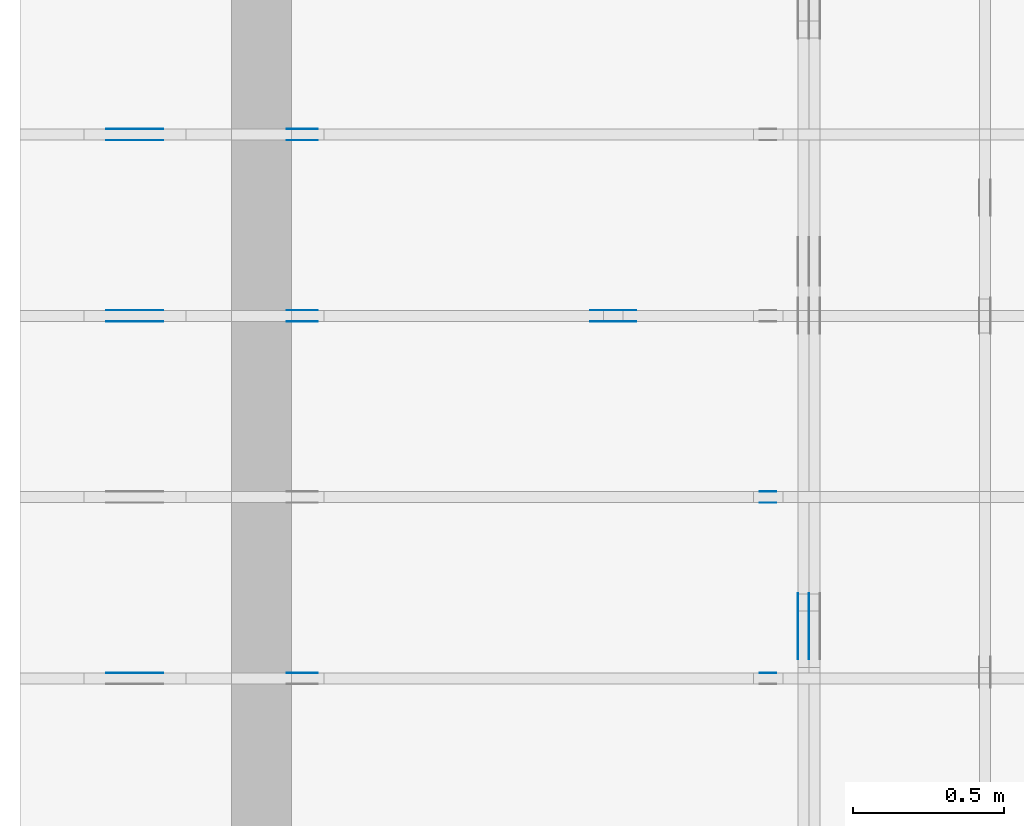
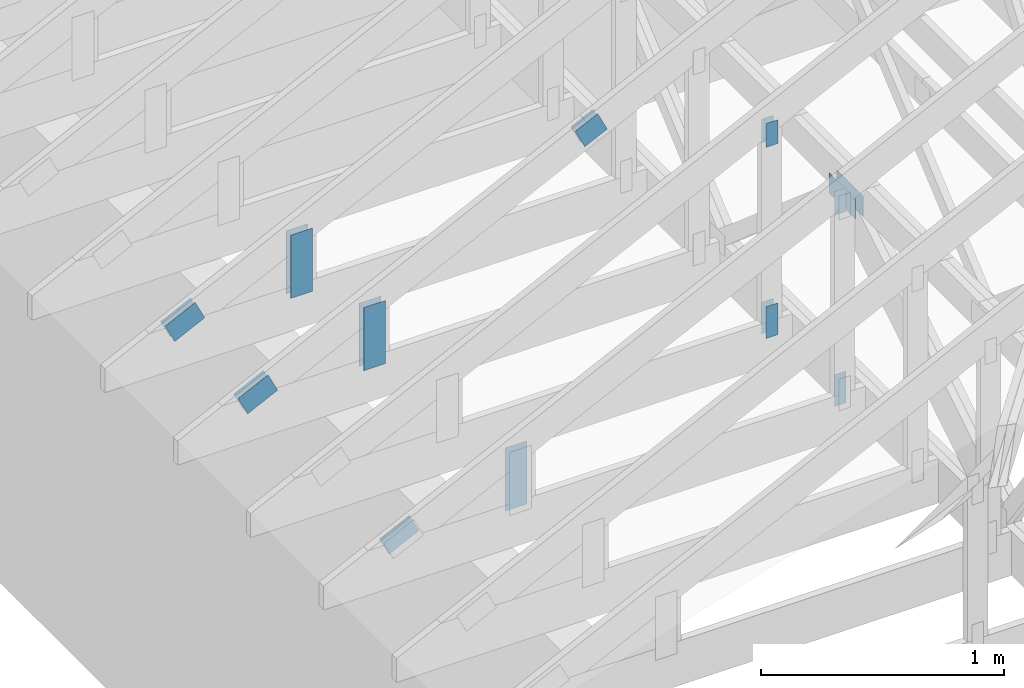
# One storey, part 65 of 159: 20 plates, 5 elements without a shape of their own.
"""IFC2X3 building model written with IfcOpenShell, lengths in millimetres."""

from ifc_helpers import new_model, si_unit, frame, origin, origin_with_axes, origin_2d, place, context, project, spatial, faceted_brep, element, aggregate, save


model = new_model("IFC2X3")

# Units and contexts
model_context = context("Model", 3, precision=1e-05, world=origin())
plan_context = context("Plan", 2, precision=1e-05, world=origin_2d())
ifc_project = project(units=[si_unit("LENGTHUNIT", "METRE", prefix="MILLI"), si_unit("AREAUNIT", "SQUARE_METRE"), si_unit("VOLUMEUNIT", "CUBIC_METRE"), si_unit("SOLIDANGLEUNIT", "STERADIAN"), si_unit("PLANEANGLEUNIT", "RADIAN"), si_unit("MASSUNIT", "GRAM"), si_unit("TIMEUNIT", "SECOND"), si_unit("THERMODYNAMICTEMPERATUREUNIT", "DEGREE_CELSIUS"), si_unit("LUMINOUSINTENSITYUNIT", "LUMEN")], contexts=[model_context, plan_context])

# Site, building, storey
site_placement = place(None, origin_with_axes())
site = spatial("IfcSite", under=ifc_project, at=site_placement, CompositionType="ELEMENT")
building_placement = place(site_placement, origin_with_axes())
building = spatial("IfcBuilding", under=site, at=building_placement, Name="Plan 1", CompositionType="ELEMENT")
storey_placement = place(building_placement, origin_with_axes())
storey = spatial("IfcBuildingStorey", under=building, at=storey_placement, Name="Etasje 1", CompositionType="ELEMENT", Elevation=0.0)

# Assembly, plates
assembly_1_placement = place(storey_placement, frame((-700.000000000007, 4482.000534935255, 1.1021457184401395e-15), z_axis=(0.0, -1.0, 6.123031769111886e-17), x_axis=(1.0, 0.0, 0.0)))
assembly_1 = element("IfcElementAssembly", 1, at=assembly_1_placement, inside=storey, Name="S1 (23)", AssemblyPlace="FACTORY", PredefinedType="TRUSS")
plate_1_placement = place(assembly_1_placement, frame((331.1100183694873, 141.8615904247371, 0.0), z_axis=(0.0, 0.0, 1.0), x_axis=(0.8987940462991673, 0.43837114678907735, 0.0)))
plate_1 = element("IfcPlate", 2, at=plate_1_placement, Name="GNT100S 103x159", context=model_context, shape_type="Brep", body=[
    faceted_brep([(158.99998918560436, 103.00001264929408, 1.0), (1.0552279888997873e-05, 103.00001264929408, 1.0), (3.170298271015781e-06, 1.2203795506593451e-05, 1.0), (159.0000092326402, 1.2203795506593451e-05, 1.0), (1.0552279888997873e-05, 103.00001264929408, 1.2922388999378885e-21), (158.99998918560436, 103.00001264929408, 1.947123970143804e-14), (159.0000092326402, 0.0, 1.9471242156410782e-14), (3.170298271015781e-06, 0.0, 3.8823674061980226e-22), (159.0000000000001, 1.1149522122547493e-05, 4.8075085841285717e-32), (159.0000000000001, 1.1149522122608723e-05, 1.0), (5.684341886080802e-14, 1.1149522151815584e-05, 1.0), (5.684341886080802e-14, 1.1149522151754354e-05, 0.0), (159.0000000000001, 103.00001114952212, 0.0), (159.0000000000001, 103.00001114952212, 1.0), (159.0000000000001, 1.1149522123332645e-05, 1.0), (159.0000000000001, 1.1149522123332645e-05, 0.0), (0.0, 103.00001114952218, 0.0), (0.0, 103.00001114952218, 1.0), (159.0000000000001, 103.00001114952214, 1.0), (159.0000000000001, 103.00001114952214, 7.888609052210118e-31), (5.684342142797745e-14, 1.1149522151754354e-05, -1.571885995307892e-37), (5.690465174566857e-14, 1.1149522151754354e-05, 1.0), (2.377690857548259e-14, 103.00001114952218, 1.0), (2.371567825779147e-14, 103.00001114952218, -1.4521185139849321e-30)], [[[0, 1, 2, 3]], [[4, 5, 6, 7]], [[8, 9, 10, 11]], [[12, 13, 14, 15]], [[16, 17, 18, 19]], [[20, 21, 22, 23]]]),
])
plate_2_placement = place(assembly_1_placement, frame((331.1100183694873, 141.8615904247371, -37.00000000000001), z_axis=(0.0, 0.0, 1.0), x_axis=(0.8987940462991673, 0.43837114678907735, 0.0)))
plate_2 = element("IfcPlate", 3, at=plate_2_placement, Name="GNT100S 103x159", context=model_context, shape_type="Brep", body=[
    faceted_brep([(158.99998918560436, 103.00001264929408, 1.0), (1.0552279888997873e-05, 103.00001264929408, 1.0), (3.170298271015781e-06, 1.2203795506593451e-05, 1.0), (159.0000092326402, 1.2203795506593451e-05, 1.0), (1.0552279888997873e-05, 103.00001264929408, 1.2922388999378885e-21), (158.99998918560436, 103.00001264929408, 1.947123970143804e-14), (159.0000092326402, 0.0, 1.9471242156410782e-14), (3.170298271015781e-06, 0.0, 3.8823674061980226e-22), (159.0000000000001, 1.1149522122547493e-05, 4.8075085841285717e-32), (159.0000000000001, 1.1149522122608723e-05, 1.0), (5.684341886080802e-14, 1.1149522151815584e-05, 1.0), (5.684341886080802e-14, 1.1149522151754354e-05, 0.0), (159.0000000000001, 103.00001114952212, 0.0), (159.0000000000001, 103.00001114952212, 1.0), (159.0000000000001, 1.1149522123332645e-05, 1.0), (159.0000000000001, 1.1149522123332645e-05, 0.0), (0.0, 103.00001114952218, 0.0), (0.0, 103.00001114952218, 1.0), (159.0000000000001, 103.00001114952214, 1.0), (159.0000000000001, 103.00001114952214, 7.888609052210118e-31), (5.684342142797745e-14, 1.1149522151754354e-05, -1.571885995307892e-37), (5.690465174566857e-14, 1.1149522151754354e-05, 1.0), (2.377690857548259e-14, 103.00001114952218, 1.0), (2.371567825779147e-14, 103.00001114952218, -1.4521185139849321e-30)], [[[0, 1, 2, 3]], [[4, 5, 6, 7]], [[8, 9, 10, 11]], [[12, 13, 14, 15]], [[16, 17, 18, 19]], [[20, 21, 22, 23]]]),
])
plate_3_placement = place(assembly_1_placement, frame((986.0125131960367, 165.43966674804688, 0.0), z_axis=(0.0, 0.0, 1.0), x_axis=(6.123031769111886e-17, 1.0, 0.0)))
plate_3 = element("IfcPlate", 4, at=plate_3_placement, Name="GNT100S 103x317", context=model_context, shape_type="Brep", body=[
    faceted_brep([(317.0, 103.00000098900546, 1.0), (0.0, 103.00000098900546, 1.0), (0.0, 9.89005457086023e-07, 1.0), (317.0, 9.89005457086023e-07, 1.0), (0.0, 103.00000098900546, 0.0), (317.0, 103.00000098900546, 3.882002141616936e-14), (317.0, 9.89005457086023e-07, 3.882002141616936e-14), (0.0, 9.89005457086023e-07, 0.0), (317.0000058634589, -5.82300332013184e-14, 3.565443432081125e-30), (317.0000058634589, -5.816880288362728e-14, 1.0), (5.863458909516339e-06, 6.122924062676347e-17, 1.0), (5.863458909516339e-06, -1.0770643553955205e-21, 6.594899265464787e-38), (317.0000058634589, 103.0, 0.0), (317.0000058634589, 103.0, 1.0), (317.0000058634589, 0.0, 1.0), (317.0000058634589, 0.0, 0.0), (5.863458909516339e-06, 103.0, 0.0), (5.863458909516339e-06, 103.0, 1.0), (317.0000058634589, 102.99999999999999, 1.0), (317.0000058634589, 102.99999999999999, -1.5777218104420236e-30), (5.863458909516339e-06, 0.0, 0.0), (5.8634589095775695e-06, -7.498303609110687e-33, 1.0), (5.863458922191015e-06, 103.0, 1.0), (5.863458922129785e-06, 103.0, -7.723252732077687e-31)], [[[0, 1, 2, 3]], [[4, 5, 6, 7]], [[8, 9, 10, 11]], [[12, 13, 14, 15]], [[16, 17, 18, 19]], [[20, 21, 22, 23]]]),
])
plate_4_placement = place(assembly_1_placement, frame((986.0125131960367, 165.43966674804688, -37.0), z_axis=(0.0, 0.0, 1.0), x_axis=(6.123031769111886e-17, 1.0, 0.0)))
plate_4 = element("IfcPlate", 5, at=plate_4_placement, Name="GNT100S 103x317", context=model_context, shape_type="Brep", body=[
    faceted_brep([(317.0, 103.00000098900546, 1.0), (0.0, 103.00000098900546, 1.0), (0.0, 9.89005457086023e-07, 1.0), (317.0, 9.89005457086023e-07, 1.0), (0.0, 103.00000098900546, 0.0), (317.0, 103.00000098900546, 3.882002141616936e-14), (317.0, 9.89005457086023e-07, 3.882002141616936e-14), (0.0, 9.89005457086023e-07, 0.0), (317.0000058634589, -5.82300332013184e-14, 3.565443432081125e-30), (317.0000058634589, -5.816880288362728e-14, 1.0), (5.863458909516339e-06, 6.122924062676347e-17, 1.0), (5.863458909516339e-06, -1.0770643553955205e-21, 6.594899265464787e-38), (317.0000058634589, 103.0, 0.0), (317.0000058634589, 103.0, 1.0), (317.0000058634589, 0.0, 1.0), (317.0000058634589, 0.0, 0.0), (5.863458909516339e-06, 103.0, 0.0), (5.863458909516339e-06, 103.0, 1.0), (317.0000058634589, 102.99999999999999, 1.0), (317.0000058634589, 102.99999999999999, -1.5777218104420236e-30), (5.863458909516339e-06, 0.0, 0.0), (5.8634589095775695e-06, -7.498303609110687e-33, 1.0), (5.863458922191015e-06, 103.0, 1.0), (5.863458922129785e-06, 103.0, -7.723252732077687e-31)], [[[0, 1, 2, 3]], [[4, 5, 6, 7]], [[8, 9, 10, 11]], [[12, 13, 14, 15]], [[16, 17, 18, 19]], [[20, 21, 22, 23]]]),
])
plate_5_placement = place(assembly_1_placement, frame((1932.9423828125007, 923.1274414062502, 0.0), z_axis=(0.0, 0.0, 1.0), x_axis=(0.8987940462991673, 0.43837114678907735, 0.0)))
plate_5 = element("IfcPlate", 6, at=plate_5_placement, Name="GNT100S 103x119", context=model_context, shape_type="Brep", body=[
    faceted_brep([(119.00004770909891, 103.00001416000737, 1.0), (1.4070994438952766e-05, 103.00001416000737, 1.0), (0.0, 0.0, 1.0), (119.00006039415575, 0.0, 1.0), (1.4070994438952766e-05, 103.00001416000737, 1.7231429194540894e-21), (119.00004770909891, 103.00001416000737, 1.4572821452972854e-14), (119.00006039415575, 6.439198386942735e-06, 1.4572823006392977e-14), (0.0, 6.439198386942735e-06, 0.0), (119.0000491479459, 6.275306616022548e-06, 1.8278989817433488e-30), (119.0000491479459, 6.2753066160837785e-06, 1.0), (4.9147945446748054e-05, 6.27530653224977e-06, 1.0), (4.9147945446748054e-05, 6.27530653218854e-06, 7.52316384526264e-37), (119.0000491479459, 103.00000627530653, 2.68212707775144e-29), (119.0000491479459, 103.00000627530653, 1.0), (119.0000491479459, 6.275306645875389e-06, 1.0), (119.0000491479459, 6.275306645875389e-06, 0.0), (4.9147945901495405e-05, 103.00000627530653, 0.0), (4.9147945901495405e-05, 103.00000627530653, 1.0), (119.00004914794545, 103.00000627530652, 1.0), (119.00004914794545, 103.00000627530652, -7.888609052210118e-31), (4.9147945446748054e-05, 6.2753065321885515e-06, -3.76158192263132e-37), (4.9147945446809284e-05, 6.2753065321885515e-06, 1.0), (4.9147945916834616e-05, 103.00000627530653, 1.0), (4.9147945916773385e-05, 103.00000627530653, -9.354757076612205e-31)], [[[0, 1, 2, 3]], [[4, 5, 6, 7]], [[8, 9, 10, 11]], [[12, 13, 14, 15]], [[16, 17, 18, 19]], [[20, 21, 22, 23]]]),
])
plate_6_placement = place(assembly_1_placement, frame((1932.9423828125007, 923.1274414062502, -37.00000000000001), z_axis=(0.0, 0.0, 1.0), x_axis=(0.8987940462991673, 0.43837114678907735, 0.0)))
plate_6 = element("IfcPlate", 7, at=plate_6_placement, Name="GNT100S 103x119", context=model_context, shape_type="Brep", body=[
    faceted_brep([(119.00004770909891, 103.00001416000737, 1.0), (1.4070994438952766e-05, 103.00001416000737, 1.0), (0.0, 0.0, 1.0), (119.00006039415575, 0.0, 1.0), (1.4070994438952766e-05, 103.00001416000737, 1.7231429194540894e-21), (119.00004770909891, 103.00001416000737, 1.4572821452972854e-14), (119.00006039415575, 6.439198386942735e-06, 1.4572823006392977e-14), (0.0, 6.439198386942735e-06, 0.0), (119.0000491479459, 6.275306616022548e-06, 1.8278989817433488e-30), (119.0000491479459, 6.2753066160837785e-06, 1.0), (4.9147945446748054e-05, 6.27530653224977e-06, 1.0), (4.9147945446748054e-05, 6.27530653218854e-06, 7.52316384526264e-37), (119.0000491479459, 103.00000627530653, 2.68212707775144e-29), (119.0000491479459, 103.00000627530653, 1.0), (119.0000491479459, 6.275306645875389e-06, 1.0), (119.0000491479459, 6.275306645875389e-06, 0.0), (4.9147945901495405e-05, 103.00000627530653, 0.0), (4.9147945901495405e-05, 103.00000627530653, 1.0), (119.00004914794545, 103.00000627530652, 1.0), (119.00004914794545, 103.00000627530652, -7.888609052210118e-31), (4.9147945446748054e-05, 6.2753065321885515e-06, -3.76158192263132e-37), (4.9147945446809284e-05, 6.2753065321885515e-06, 1.0), (4.9147945916834616e-05, 103.00000627530653, 1.0), (4.9147945916773385e-05, 103.00000627530653, -9.354757076612205e-31)], [[[0, 1, 2, 3]], [[4, 5, 6, 7]], [[8, 9, 10, 11]], [[12, 13, 14, 15]], [[16, 17, 18, 19]], [[20, 21, 22, 23]]]),
])
aggregate(assembly_1, [plate_1, plate_2, plate_3, plate_4, plate_5, plate_6])

assembly_2_placement = place(storey_placement, frame((-700.000000000007, 3882.0074014212605, 1.1021457184401395e-15), z_axis=(0.0, -1.0, 6.123031769111886e-17), x_axis=(1.0, 0.0, 0.0)))
assembly_2 = element("IfcElementAssembly", 8, at=assembly_2_placement, inside=storey, Name="S2 (21)", AssemblyPlace="FACTORY", PredefinedType="TRUSS")
plate_7_placement = place(assembly_2_placement, frame((2448.522216796875, 1222.4716796875, 0.0), z_axis=(0.0, 0.0, 1.0), x_axis=(6.123031769111886e-17, -1.0, 0.0)))
plate_7 = element("IfcPlate", 9, at=plate_7_placement, Name="GNT100S 55x119", context=model_context, shape_type="Brep", body=[
    faceted_brep([(119.0, 55.0, 1.0), (0.0, 55.0, 1.0), (0.0, 0.0, 1.0), (119.0, 0.0, 1.0), (0.0, 55.0, 0.0), (119.0, 55.0, 1.457281561048629e-14), (119.0, 0.0, 1.457281561048629e-14), (0.0, 0.0, 0.0), (119.00001997548839, 4.460947864205584e-05, 1.3384475843434453e-30), (119.00001997548839, 4.460947864211707e-05, 1.0), (1.9975488385171047e-05, 4.460947866397629e-05, 1.0), (1.9975488385171047e-05, 4.460947866391506e-05, 3.76158192263132e-37), (119.00001997548839, 55.000044609478664, 0.0), (119.00001997548839, 55.000044609478664, 1.0), (119.00001997548839, 4.460947866391507e-05, 1.0), (119.00001997548839, 4.460947866391507e-05, 0.0), (1.9975488385171047e-05, 55.000044609478664, 0.0), (1.9975488385171047e-05, 55.000044609478664, 1.0), (119.00001997548839, 55.00004460947866, 1.0), (119.00001997548839, 55.00004460947866, -3.944304526105059e-31), (1.9975488385171054e-05, 4.460947866391507e-05, -3.76158192263132e-37), (1.9975488385232285e-05, 4.460947866391507e-05, 1.0), (1.997548839196762e-05, 55.000044609478664, 1.0), (1.997548839190639e-05, 55.000044609478664, -4.12407052618761e-31)], [[[0, 1, 2, 3]], [[4, 5, 6, 7]], [[8, 9, 10, 11]], [[12, 13, 14, 15]], [[16, 17, 18, 19]], [[20, 21, 22, 23]]]),
])
plate_8_placement = place(assembly_2_placement, frame((2448.522216796875, 1222.4716796875, -37.0), z_axis=(0.0, 0.0, 1.0), x_axis=(6.123031769111886e-17, -1.0, 0.0)))
plate_8 = element("IfcPlate", 10, at=plate_8_placement, Name="GNT100S 55x119", context=model_context, shape_type="Brep", body=[
    faceted_brep([(119.0, 55.0, 1.0), (0.0, 55.0, 1.0), (0.0, 0.0, 1.0), (119.0, 0.0, 1.0), (0.0, 55.0, 0.0), (119.0, 55.0, 1.457281561048629e-14), (119.0, 0.0, 1.457281561048629e-14), (0.0, 0.0, 0.0), (119.00001997548839, 4.460947864205584e-05, 1.3384475843434453e-30), (119.00001997548839, 4.460947864211707e-05, 1.0), (1.9975488385171047e-05, 4.460947866397629e-05, 1.0), (1.9975488385171047e-05, 4.460947866391506e-05, 3.76158192263132e-37), (119.00001997548839, 55.000044609478664, 0.0), (119.00001997548839, 55.000044609478664, 1.0), (119.00001997548839, 4.460947866391507e-05, 1.0), (119.00001997548839, 4.460947866391507e-05, 0.0), (1.9975488385171047e-05, 55.000044609478664, 0.0), (1.9975488385171047e-05, 55.000044609478664, 1.0), (119.00001997548839, 55.00004460947866, 1.0), (119.00001997548839, 55.00004460947866, -3.944304526105059e-31), (1.9975488385171054e-05, 4.460947866391507e-05, -3.76158192263132e-37), (1.9975488385232285e-05, 4.460947866391507e-05, 1.0), (1.997548839196762e-05, 55.000044609478664, 1.0), (1.997548839190639e-05, 55.000044609478664, -4.12407052618761e-31)], [[[0, 1, 2, 3]], [[4, 5, 6, 7]], [[8, 9, 10, 11]], [[12, 13, 14, 15]], [[16, 17, 18, 19]], [[20, 21, 22, 23]]]),
])
plate_9_placement = place(assembly_2_placement, frame((2503.5222614066006, 143.5, 0.0), z_axis=(0.0, 0.0, 1.0), x_axis=(6.123031769111886e-17, 1.0, 0.0)))
plate_9 = element("IfcPlate", 11, at=plate_9_placement, Name="GNT100S 55x159", context=model_context, shape_type="Brep", body=[
    faceted_brep([(159.00000000000003, 55.00004460972559, 1.0), (0.0, 55.00004460972559, 1.0), (0.0, 4.46097255917266e-05, 1.0), (159.00000000000003, 4.46097255917266e-05, 1.0), (0.0, 55.00004460972559, 0.0), (159.00000000000003, 55.00004460972559, 1.94712410257758e-14), (159.00000000000003, 4.46097255917266e-05, 1.94712410257758e-14), (0.0, 4.46097255917266e-05, 0.0), (159.0000000000197, -2.9206861538667314e-14, 1.7883454107731203e-30), (159.0000000000197, -2.9145631220976195e-14, 1.0), (1.9696244635269977e-11, 6.123031768750084e-17, 1.0), (1.9696244635269977e-11, -3.618021949018729e-27, 2.2153263335185782e-43), (159.0000000000197, 55.0, 0.0), (159.0000000000197, 55.0, 1.0), (159.0000000000197, 0.0, 1.0), (159.0000000000197, 0.0, 0.0), (1.9696244635269977e-11, 55.0, 0.0), (1.9696244635269977e-11, 55.0, 1.0), (159.0000000000197, 54.99999999999999, 1.0), (159.0000000000197, 54.99999999999999, -7.888609052210118e-31), (1.9696244635269977e-11, 0.0, 0.0), (1.9696305865587668e-11, -7.498303609110687e-33, 1.0), (1.970304120053369e-11, 55.0, 1.0), (1.9702979970216e-11, 55.0, -4.124066985010878e-31)], [[[0, 1, 2, 3]], [[4, 5, 6, 7]], [[8, 9, 10, 11]], [[12, 13, 14, 15]], [[16, 17, 18, 19]], [[20, 21, 22, 23]]]),
])
plate_10_placement = place(assembly_2_placement, frame((2503.5222614066006, 143.5, -37.0), z_axis=(0.0, 0.0, 1.0), x_axis=(6.123031769111886e-17, 1.0, 0.0)))
plate_10 = element("IfcPlate", 12, at=plate_10_placement, Name="GNT100S 55x159", context=model_context, shape_type="Brep", body=[
    faceted_brep([(159.00000000000003, 55.00004460972559, 1.0), (0.0, 55.00004460972559, 1.0), (0.0, 4.46097255917266e-05, 1.0), (159.00000000000003, 4.46097255917266e-05, 1.0), (0.0, 55.00004460972559, 0.0), (159.00000000000003, 55.00004460972559, 1.94712410257758e-14), (159.00000000000003, 4.46097255917266e-05, 1.94712410257758e-14), (0.0, 4.46097255917266e-05, 0.0), (159.0000000000197, -2.9206861538667314e-14, 1.7883454107731203e-30), (159.0000000000197, -2.9145631220976195e-14, 1.0), (1.9696244635269977e-11, 6.123031768750084e-17, 1.0), (1.9696244635269977e-11, -3.618021949018729e-27, 2.2153263335185782e-43), (159.0000000000197, 55.0, 0.0), (159.0000000000197, 55.0, 1.0), (159.0000000000197, 0.0, 1.0), (159.0000000000197, 0.0, 0.0), (1.9696244635269977e-11, 55.0, 0.0), (1.9696244635269977e-11, 55.0, 1.0), (159.0000000000197, 54.99999999999999, 1.0), (159.0000000000197, 54.99999999999999, -7.888609052210118e-31), (1.9696244635269977e-11, 0.0, 0.0), (1.9696305865587668e-11, -7.498303609110687e-33, 1.0), (1.970304120053369e-11, 55.0, 1.0), (1.9702979970216e-11, 55.0, -4.124066985010878e-31)], [[[0, 1, 2, 3]], [[4, 5, 6, 7]], [[8, 9, 10, 11]], [[12, 13, 14, 15]], [[16, 17, 18, 19]], [[20, 21, 22, 23]]]),
])
aggregate(assembly_2, [plate_7, plate_8, plate_9, plate_10])

assembly_3_placement = place(storey_placement, frame((-700.000000000007, 3282.0074014212605, 1.1021457184401395e-15), z_axis=(0.0, -1.0, 6.123031769111886e-17), x_axis=(1.0, 0.0, 0.0)))
assembly_3 = element("IfcElementAssembly", 13, at=assembly_3_placement, inside=storey, Name="S3 (19)", AssemblyPlace="FACTORY", PredefinedType="TRUSS")
plate_11_placement = place(assembly_3_placement, frame((2448.522216796875, 1222.4716796875, -37.0), z_axis=(0.0, 0.0, 1.0), x_axis=(6.123031769111886e-17, -1.0, 0.0)))
plate_11 = element("IfcPlate", 14, at=plate_11_placement, Name="GNT100S 55x119", context=model_context, shape_type="Brep", body=[
    faceted_brep([(119.0, 55.0, 1.0), (0.0, 55.0, 1.0), (0.0, 0.0, 1.0), (119.0, 0.0, 1.0), (0.0, 55.0, 0.0), (119.0, 55.0, 1.457281561048629e-14), (119.0, 0.0, 1.457281561048629e-14), (0.0, 0.0, 0.0), (119.0000199755325, 4.4609676457153475e-05, 1.3384475843434453e-30), (119.0000199755325, 4.4609676457214706e-05, 1.0), (1.9975532495664083e-05, 4.460967647907393e-05, 1.0), (1.9975532495664083e-05, 4.46096764790127e-05, 3.76158192263132e-37), (119.0000199755325, 55.00004460967648, 0.0), (119.0000199755325, 55.00004460967648, 1.0), (119.0000199755325, 4.4609676479012705e-05, 1.0), (119.0000199755325, 4.4609676479012705e-05, 0.0), (1.9975532495664083e-05, 55.00004460967648, 0.0), (1.9975532495664083e-05, 55.00004460967648, 1.0), (119.0000199755325, 55.00004460967647, 1.0), (119.0000199755325, 55.00004460967647, -3.944304526105059e-31), (1.997553249566409e-05, 4.4609676479012705e-05, -3.76158192263132e-37), (1.997553249572532e-05, 4.4609676479012705e-05, 1.0), (1.9975532502460655e-05, 55.00004460967648, 1.0), (1.9975532502399425e-05, 55.00004460967648, -4.12407052618761e-31)], [[[0, 1, 2, 3]], [[4, 5, 6, 7]], [[8, 9, 10, 11]], [[12, 13, 14, 15]], [[16, 17, 18, 19]], [[20, 21, 22, 23]]]),
])
plate_12_placement = place(assembly_3_placement, frame((2503.5222614066006, 143.5, -37.0), z_axis=(0.0, 0.0, 1.0), x_axis=(6.123031769111886e-17, 1.0, 0.0)))
plate_12 = element("IfcPlate", 15, at=plate_12_placement, Name="GNT100S 55x159", context=model_context, shape_type="Brep", body=[
    faceted_brep([(159.00000000000003, 55.00004460972559, 1.0), (0.0, 55.00004460972559, 1.0), (0.0, 4.46097255917266e-05, 1.0), (159.00000000000003, 4.46097255917266e-05, 1.0), (0.0, 55.00004460972559, 0.0), (159.00000000000003, 55.00004460972559, 1.94712410257758e-14), (159.00000000000003, 4.46097255917266e-05, 1.94712410257758e-14), (0.0, 4.46097255917266e-05, 0.0), (159.0000000000197, -2.9206861538667314e-14, 1.7883454107731203e-30), (159.0000000000197, -2.9145631220976195e-14, 1.0), (1.9696244635269977e-11, 6.123031768750084e-17, 1.0), (1.9696244635269977e-11, -3.618021949018729e-27, 2.2153263335185782e-43), (159.0000000000197, 55.0, 0.0), (159.0000000000197, 55.0, 1.0), (159.0000000000197, 0.0, 1.0), (159.0000000000197, 0.0, 0.0), (1.9696244635269977e-11, 55.0, 0.0), (1.9696244635269977e-11, 55.0, 1.0), (159.0000000000197, 54.99999999999999, 1.0), (159.0000000000197, 54.99999999999999, -7.888609052210118e-31), (1.9696244635269977e-11, 0.0, 0.0), (1.9696305865587668e-11, -7.498303609110687e-33, 1.0), (1.970304120053369e-11, 55.0, 1.0), (1.9702979970216e-11, 55.0, -4.124066985010878e-31)], [[[0, 1, 2, 3]], [[4, 5, 6, 7]], [[8, 9, 10, 11]], [[12, 13, 14, 15]], [[16, 17, 18, 19]], [[20, 21, 22, 23]]]),
])
plate_13_placement = place(assembly_3_placement, frame((331.11001837023963, 141.861590425104, -37.00000000000001), z_axis=(0.0, 0.0, 1.0), x_axis=(0.898794046299167, 0.4383711467890774, 0.0)))
plate_13 = element("IfcPlate", 16, at=plate_13_placement, Name="GNT100S 103x159", context=model_context, shape_type="Brep", body=[
    faceted_brep([(158.9999891847673, 103.00001264929412, 1.0), (1.0551442869655148e-05, 103.00001264929412, 1.0), (3.169461194829637e-06, 1.220379553501516e-05, 1.0), (159.00000923180312, 1.220379553501516e-05, 1.0), (1.0551442869655148e-05, 103.00001264929412, 1.2921363980173511e-21), (158.9999891847673, 103.00001264929412, 1.9471239701335528e-14), (159.00000923180312, 0.0, 1.9471242156308275e-14), (3.169461194829637e-06, 0.0, 3.881342317381837e-22), (159.0000000000001, 1.1149113816269815e-05, 4.8075085841285717e-32), (159.0000000000001, 1.1149113816331046e-05, 1.0), (5.684341886080802e-14, 1.1149113845537907e-05, 1.0), (5.684341886080802e-14, 1.1149113845476677e-05, 0.0), (159.0000000000001, 103.00001114911387, 6.310887241768095e-30), (159.0000000000001, 103.00001114911387, 1.0), (159.0000000000001, 1.1149113817054968e-05, 1.0), (159.0000000000001, 1.1149113817054968e-05, 0.0), (0.0, 103.00001114911385, 0.0), (0.0, 103.00001114911385, 1.0), (159.0, 103.00001114911387, 1.0), (159.0, 103.00001114911387, 0.0), (5.684342142788343e-14, 1.1149113845476677e-05, -1.5718284369734698e-37), (5.690465174557455e-14, 1.1149113845476677e-05, 1.0), (2.3776908575388583e-14, 103.00001114911385, 1.0), (2.3715678257697464e-14, 103.00001114911385, -1.4521185139791763e-30)], [[[0, 1, 2, 3]], [[4, 5, 6, 7]], [[8, 9, 10, 11]], [[12, 13, 14, 15]], [[16, 17, 18, 19]], [[20, 21, 22, 23]]]),
])
plate_14_placement = place(assembly_3_placement, frame((986.0125131974362, 165.43966674804688, -37.0), z_axis=(0.0, 0.0, 1.0), x_axis=(6.123031769111886e-17, 1.0, 0.0)))
plate_14 = element("IfcPlate", 17, at=plate_14_placement, Name="GNT100S 103x317", context=model_context, shape_type="Brep", body=[
    faceted_brep([(317.0, 103.00000099040494, 1.0), (0.0, 103.00000099040494, 1.0), (0.0, 9.90404942058376e-07, 1.0), (317.0, 9.90404942058376e-07, 1.0), (0.0, 103.00000099040494, 0.0), (317.0, 103.00000099040494, 3.882002141616936e-14), (317.0, 9.90404942058376e-07, 3.882002141616936e-14), (0.0, 9.90404942058376e-07, 0.0), (317.0000058634298, -5.823003320131305e-14, 3.565443432080797e-30), (317.0000058634298, -5.816880288362193e-14, 1.0), (5.8634298056858825e-06, 6.122924063210958e-17, 1.0), (5.8634298056858825e-06, -1.0770590092851658e-21, 6.594866531061244e-38), (317.0000058634298, 103.0, 0.0), (317.0000058634298, 103.0, 1.0), (317.0000058634298, 0.0, 1.0), (317.0000058634298, 0.0, 0.0), (5.8634298056858825e-06, 103.0, 0.0), (5.8634298056858825e-06, 103.0, 1.0), (317.0000058634298, 102.99999999999999, 1.0), (317.0000058634298, 102.99999999999999, -1.5777218104420236e-30), (5.8634298056858825e-06, 0.0, 0.0), (5.863429805747113e-06, -7.498303609110687e-33, 1.0), (5.863429818360558e-06, 103.0, 1.0), (5.863429818299328e-06, 103.0, -7.723252732077687e-31)], [[[0, 1, 2, 3]], [[4, 5, 6, 7]], [[8, 9, 10, 11]], [[12, 13, 14, 15]], [[16, 17, 18, 19]], [[20, 21, 22, 23]]]),
])
aggregate(assembly_3, [plate_11, plate_12, plate_13, plate_14])

assembly_4_placement = place(storey_placement, frame((-700.000000000007, 5081.993668449246, 1.1021457184401395e-15), z_axis=(0.0, -1.0, 6.123031769111886e-17), x_axis=(1.0, 0.0, 0.0)))
assembly_4 = element("IfcElementAssembly", 18, at=assembly_4_placement, inside=storey, Name="S2 (15)", AssemblyPlace="FACTORY", PredefinedType="TRUSS")
plate_15_placement = place(assembly_4_placement, frame((331.11001836948736, 141.86159042473713, 0.0), z_axis=(0.0, 0.0, 1.0), x_axis=(0.8987940462991673, 0.43837114678907735, 0.0)))
plate_15 = element("IfcPlate", 19, at=plate_15_placement, Name="GNT100S 103x159", context=model_context, shape_type="Brep", body=[
    faceted_brep([(158.9999891856043, 103.00001264929408, 1.0), (1.0552279832154454e-05, 103.00001264929408, 1.0), (3.1702982141723623e-06, 1.2203795506593451e-05, 1.0), (159.00000923264014, 1.2203795506593451e-05, 1.0), (1.0552279832154454e-05, 103.00001264929408, 1.2922388929768073e-21), (158.9999891856043, 103.00001264929408, 1.947123970143803e-14), (159.00000923264014, 0.0, 1.9471242156410776e-14), (3.1702982141723623e-06, 0.0, 3.8823673365872107e-22), (159.00000000000006, 1.1149522065704074e-05, 3.5286156813378984e-30), (159.00000000000006, 1.1149522065765304e-05, 1.0), (5.684341886080802e-14, 1.1149522094972166e-05, 1.0), (5.684341886080802e-14, 1.1149522094910935e-05, 0.0), (159.00000000000006, 103.00001114952212, 0.0), (159.00000000000006, 103.00001114952212, 1.0), (159.00000000000006, 1.1149522123332645e-05, 1.0), (159.00000000000006, 1.1149522123332645e-05, 0.0), (0.0, 103.00001114952211, 0.0), (0.0, 103.00001114952211, 1.0), (159.00000000000009, 103.00001114952214, 1.0), (159.00000000000009, 103.00001114952214, 7.888609052210118e-31), (5.684342142797743e-14, 1.1149522094910935e-05, -1.571885995307892e-37), (5.690465174566855e-14, 1.1149522094910935e-05, 1.0), (2.377690857548259e-14, 103.00001114952211, 1.0), (2.371567825779147e-14, 103.00001114952211, -1.4521185139849321e-30)], [[[0, 1, 2, 3]], [[4, 5, 6, 7]], [[8, 9, 10, 11]], [[12, 13, 14, 15]], [[16, 17, 18, 19]], [[20, 21, 22, 23]]]),
])
plate_16_placement = place(assembly_4_placement, frame((331.11001836948736, 141.86159042473713, -37.00000000000001), z_axis=(0.0, 0.0, 1.0), x_axis=(0.8987940462991673, 0.43837114678907735, 0.0)))
plate_16 = element("IfcPlate", 20, at=plate_16_placement, Name="GNT100S 103x159", context=model_context, shape_type="Brep", body=[
    faceted_brep([(158.9999891856043, 103.00001264929408, 1.0), (1.0552279832154454e-05, 103.00001264929408, 1.0), (3.1702982141723623e-06, 1.2203795506593451e-05, 1.0), (159.00000923264014, 1.2203795506593451e-05, 1.0), (1.0552279832154454e-05, 103.00001264929408, 1.2922388929768073e-21), (158.9999891856043, 103.00001264929408, 1.947123970143803e-14), (159.00000923264014, 0.0, 1.9471242156410776e-14), (3.1702982141723623e-06, 0.0, 3.8823673365872107e-22), (159.00000000000006, 1.1149522065704074e-05, 3.5286156813378984e-30), (159.00000000000006, 1.1149522065765304e-05, 1.0), (5.684341886080802e-14, 1.1149522094972166e-05, 1.0), (5.684341886080802e-14, 1.1149522094910935e-05, 0.0), (159.00000000000006, 103.00001114952212, 0.0), (159.00000000000006, 103.00001114952212, 1.0), (159.00000000000006, 1.1149522123332645e-05, 1.0), (159.00000000000006, 1.1149522123332645e-05, 0.0), (0.0, 103.00001114952211, 0.0), (0.0, 103.00001114952211, 1.0), (159.00000000000009, 103.00001114952214, 1.0), (159.00000000000009, 103.00001114952214, 7.888609052210118e-31), (5.684342142797743e-14, 1.1149522094910935e-05, -1.571885995307892e-37), (5.690465174566855e-14, 1.1149522094910935e-05, 1.0), (2.377690857548259e-14, 103.00001114952211, 1.0), (2.371567825779147e-14, 103.00001114952211, -1.4521185139849321e-30)], [[[0, 1, 2, 3]], [[4, 5, 6, 7]], [[8, 9, 10, 11]], [[12, 13, 14, 15]], [[16, 17, 18, 19]], [[20, 21, 22, 23]]]),
])
plate_17_placement = place(assembly_4_placement, frame((986.0125131959378, 165.43966674804688, 0.0), z_axis=(0.0, 0.0, 1.0), x_axis=(6.123031769111886e-17, 1.0, 0.0)))
plate_17 = element("IfcPlate", 21, at=plate_17_placement, Name="GNT100S 103x317", context=model_context, shape_type="Brep", body=[
    faceted_brep([(317.0, 103.00000098890655, 1.0), (0.0, 103.00000098890655, 1.0), (0.0, 9.889065495372051e-07, 1.0), (317.0, 9.889065495372051e-07, 1.0), (0.0, 103.00000098890655, 0.0), (317.0, 103.00000098890655, 3.882002141616936e-14), (317.0, 9.889065495372051e-07, 3.882002141616936e-14), (0.0, 9.889065495372051e-07, 0.0), (317.0000058634384, -5.823003320131462e-14, 3.5654434320808935e-30), (317.0000058634384, -5.81688028836235e-14, 1.0), (5.8634383890421304e-06, 6.12292406305329e-17, 1.0), (5.8634383890421304e-06, -1.0770605859700555e-21, 6.594876185152914e-38), (317.0000058634384, 103.0, 0.0), (317.0000058634384, 103.0, 1.0), (317.0000058634384, 0.0, 1.0), (317.0000058634384, 0.0, 0.0), (5.8634383890421304e-06, 103.0, 0.0), (5.8634383890421304e-06, 103.0, 1.0), (317.0000058634384, 102.99999999999999, 1.0), (317.0000058634384, 102.99999999999999, -1.5777218104420236e-30), (5.8634383890421304e-06, 0.0, 0.0), (5.863438389103361e-06, -7.498303609110687e-33, 1.0), (5.863438401716806e-06, 103.0, 1.0), (5.863438401655576e-06, 103.0, -7.723252732077687e-31)], [[[0, 1, 2, 3]], [[4, 5, 6, 7]], [[8, 9, 10, 11]], [[12, 13, 14, 15]], [[16, 17, 18, 19]], [[20, 21, 22, 23]]]),
])
plate_18_placement = place(assembly_4_placement, frame((986.0125131959378, 165.43966674804688, -37.0), z_axis=(0.0, 0.0, 1.0), x_axis=(6.123031769111886e-17, 1.0, 0.0)))
plate_18 = element("IfcPlate", 22, at=plate_18_placement, Name="GNT100S 103x317", context=model_context, shape_type="Brep", body=[
    faceted_brep([(317.0, 103.00000098890655, 1.0), (0.0, 103.00000098890655, 1.0), (0.0, 9.889065495372051e-07, 1.0), (317.0, 9.889065495372051e-07, 1.0), (0.0, 103.00000098890655, 0.0), (317.0, 103.00000098890655, 3.882002141616936e-14), (317.0, 9.889065495372051e-07, 3.882002141616936e-14), (0.0, 9.889065495372051e-07, 0.0), (317.0000058634384, -5.823003320131462e-14, 3.5654434320808935e-30), (317.0000058634384, -5.81688028836235e-14, 1.0), (5.8634383890421304e-06, 6.12292406305329e-17, 1.0), (5.8634383890421304e-06, -1.0770605859700555e-21, 6.594876185152914e-38), (317.0000058634384, 103.0, 0.0), (317.0000058634384, 103.0, 1.0), (317.0000058634384, 0.0, 1.0), (317.0000058634384, 0.0, 0.0), (5.8634383890421304e-06, 103.0, 0.0), (5.8634383890421304e-06, 103.0, 1.0), (317.0000058634384, 102.99999999999999, 1.0), (317.0000058634384, 102.99999999999999, -1.5777218104420236e-30), (5.8634383890421304e-06, 0.0, 0.0), (5.863438389103361e-06, -7.498303609110687e-33, 1.0), (5.863438401716806e-06, 103.0, 1.0), (5.863438401655576e-06, 103.0, -7.723252732077687e-31)], [[[0, 1, 2, 3]], [[4, 5, 6, 7]], [[8, 9, 10, 11]], [[12, 13, 14, 15]], [[16, 17, 18, 19]], [[20, 21, 22, 23]]]),
])
aggregate(assembly_4, [plate_15, plate_16, plate_17, plate_18])

assembly_5_placement = place(storey_placement, frame((1875.0222614047502, 9699.999999999993, 0.0), z_axis=(-1.0, 1.836909530733566e-16, 6.123031769111886e-17), x_axis=(-1.836909530733566e-16, -1.0, 0.0)))
assembly_5 = element("IfcElementAssembly", 23, at=assembly_5_placement, inside=storey, Name="V1 (2)", AssemblyPlace="FACTORY", PredefinedType="TRUSS")
plate_19_placement = place(assembly_5_placement, frame((6117.8147670622475, 1011.7571859793313, 0.0), z_axis=(0.0, 0.0, 1.0), x_axis=(1.0, 0.0, 0.0)))
plate_19 = element("IfcPlate", 24, at=plate_19_placement, Name="GNT100S 103x218", context=model_context, shape_type="Brep", body=[
    faceted_brep([(218.00017434400252, 103.00001616910617, 1.0), (0.000174344002516591, 103.00001616910617, 1.0), (0.000174344002516591, 1.6169106174857006e-05, 1.0), (218.00017434400252, 1.6169106174857006e-05, 1.0), (0.000174344002516591, 103.00001616910617, 2.1350277323264186e-20), (218.00017434400252, 103.00001616910617, 2.6696439863605148e-14), (218.00017434400252, 1.6169106174857006e-05, 2.6696439863605148e-14), (0.000174344002516591, 1.6169106174857006e-05, 2.1350277323264186e-20), (218.0, -4.0044627769991736e-14, 2.4519452801791947e-30), (218.0, -3.998339745230062e-14, 1.0), (1.1247455413666031e-32, 6.123031769111886e-17, 1.0), (0.0, 0.0, 0.0), (218.0, 103.0, 0.0), (218.0, 103.0, 1.0), (218.0, 0.0, 1.0), (218.0, 0.0, 0.0), (0.0, 103.0, 0.0), (-3.7491518045553436e-33, 103.0, 1.0), (218.0, 102.99999999999999, 1.0), (218.0, 102.99999999999999, -7.888609052210118e-31), (0.0, 0.0, 0.0), (6.123031769111886e-17, -7.498303609110687e-33, 1.0), (1.2674675762061605e-14, 103.0, 1.0), (1.2613445444370486e-14, 103.0, -7.723252717384008e-31)], [[[0, 1, 2, 3]], [[4, 5, 6, 7]], [[8, 9, 10, 11]], [[12, 13, 14, 15]], [[16, 17, 18, 19]], [[20, 21, 22, 23]]]),
])
plate_20_placement = place(assembly_5_placement, frame((6117.8147670622475, 1011.7571859793313, -37.0), z_axis=(0.0, 0.0, 1.0), x_axis=(1.0, 0.0, 0.0)))
plate_20 = element("IfcPlate", 25, at=plate_20_placement, Name="GNT100S 103x218", context=model_context, shape_type="Brep", body=[
    faceted_brep([(218.00017434400252, 103.00001616910617, 1.0), (0.000174344002516591, 103.00001616910617, 1.0), (0.000174344002516591, 1.6169106174857006e-05, 1.0), (218.00017434400252, 1.6169106174857006e-05, 1.0), (0.000174344002516591, 103.00001616910617, 2.1350277323264186e-20), (218.00017434400252, 103.00001616910617, 2.6696439863605148e-14), (218.00017434400252, 1.6169106174857006e-05, 2.6696439863605148e-14), (0.000174344002516591, 1.6169106174857006e-05, 2.1350277323264186e-20), (218.0, -4.0044627769991736e-14, 2.4519452801791947e-30), (218.0, -3.998339745230062e-14, 1.0), (1.1247455413666031e-32, 6.123031769111886e-17, 1.0), (0.0, 0.0, 0.0), (218.0, 103.0, 0.0), (218.0, 103.0, 1.0), (218.0, 0.0, 1.0), (218.0, 0.0, 0.0), (0.0, 103.0, 0.0), (-3.7491518045553436e-33, 103.0, 1.0), (218.0, 102.99999999999999, 1.0), (218.0, 102.99999999999999, -7.888609052210118e-31), (0.0, 0.0, 0.0), (6.123031769111886e-17, -7.498303609110687e-33, 1.0), (1.2674675762061605e-14, 103.0, 1.0), (1.2613445444370486e-14, 103.0, -7.723252717384008e-31)], [[[0, 1, 2, 3]], [[4, 5, 6, 7]], [[8, 9, 10, 11]], [[12, 13, 14, 15]], [[16, 17, 18, 19]], [[20, 21, 22, 23]]]),
])
aggregate(assembly_5, [plate_19, plate_20])

save(model, "model.ifc")
